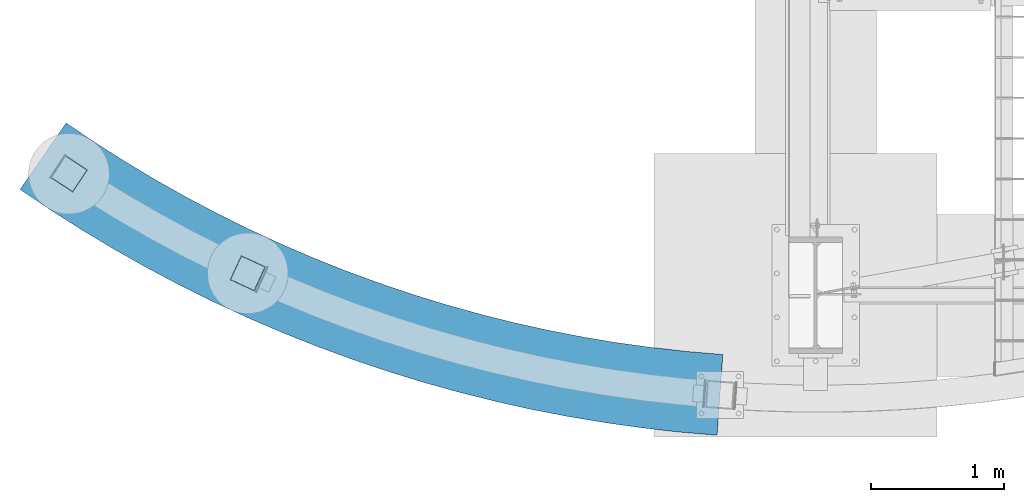
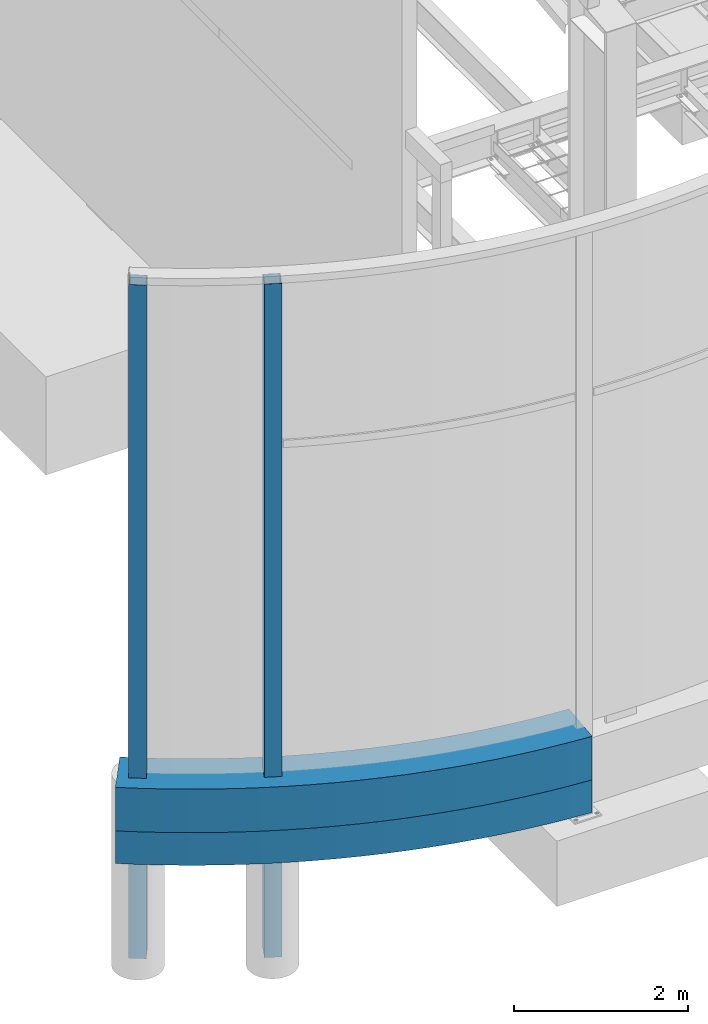
# One storey, part 699 of 1179: 4 beams, 4 elements without a shape of their own.
"""IFC2X3 building model written with IfcOpenShell, lengths in millimetres."""

from ifc_helpers import new_model, si_unit, frame, origin_with_axes, place, context, subcontext, project, spatial, faceted_brep, material, type_object, element, aggregate, save


model = new_model("IFC2X3")

# Units and contexts
model_context = context("Model", 3, precision=1e-05, world=origin_with_axes())
body_context = subcontext(model_context, "Body", "Model", "MODEL_VIEW")
ifc_project = project(units=[si_unit("LENGTHUNIT", "METRE", prefix="MILLI"), si_unit("AREAUNIT", "SQUARE_METRE"), si_unit("VOLUMEUNIT", "CUBIC_METRE"), si_unit("MASSUNIT", "GRAM", prefix="KILO"), si_unit("TIMEUNIT", "SECOND"), si_unit("PLANEANGLEUNIT", "RADIAN"), si_unit("SOLIDANGLEUNIT", "STERADIAN"), si_unit("THERMODYNAMICTEMPERATUREUNIT", "DEGREE_CELSIUS"), si_unit("LUMINOUSINTENSITYUNIT", "LUMEN")], contexts=[model_context])

# Site, building, storey
site_placement = place(None, origin_with_axes())
site = spatial("IfcSite", under=ifc_project, at=site_placement, CompositionType="ELEMENT")
building_placement = place(site_placement, origin_with_axes())
building = spatial("IfcBuilding", under=site, at=building_placement, Name="Undefined", CompositionType="ELEMENT")
storey_placement = place(building_placement, origin_with_axes())
storey = spatial("IfcBuildingStorey", under=building, at=storey_placement, Name="Undefined", CompositionType="ELEMENT", Elevation=0.0)

# Assembly, beam
assembly_1_placement = place(storey_placement, origin_with_axes())
assembly_1 = element("IfcElementAssembly", 1, at=assembly_1_placement, inside=storey, Name="GRADE_BEAM", AssemblyPlace="NOTDEFINED", PredefinedType="REINFORCEMENT_UNIT")
ifc_material_1 = material(Name="CONCRETE/5000")
beam_type_1 = type_object("IfcBeamType", PredefinedType="NOTDEFINED")
beam_1_placement = place(assembly_1_placement, frame((-5385.70183901794, 1486.40751131406, -889.000667008818), z_axis=(0.0, 0.0, 1.0), x_axis=(0.870964399060689, -0.491346126034237, 0.0)))
beam_1 = element("IfcBeam", 2, at=beam_1_placement, type_object=beam_type_1, material=ifc_material_1, Name="GRADE_BEAM", context=body_context, shape_type="Brep", body=[
    faceted_brep([(-28.3943633455974, -303.474546099302, -228.6), (-28.3943633455974, -303.474546099302, 228.6), (28.3943633455992, 303.474546099302, 228.6), (28.3943633455992, 303.474546099302, -228.6), (533.586879412836, -340.905096028998, 228.6), (815.127734137885, -348.318947941847, 228.6), (1096.76615721708, -348.189622933819, 228.6), (1378.30008451081, -340.517213790359, 228.6), (1659.52752685093, -325.307225153676, 228.6), (1940.24671495982, -302.570569573395, 228.6), (2220.25624421165, -272.323559677239, 228.6), (2499.35521913202, -234.58789646738, 228.6), (2777.34339753231, -189.390653750846, 228.6), (3054.02133417533, -136.764258715177, 228.6), (3329.19052386917, -76.7464686632229, 228.6), (3602.65354388665, -9.38034392381314, 228.6), (3874.21419560808, 65.2857830422784, 228.6), (4143.67764528583, 147.198342318925, 228.6), (4410.85056382963, 236.298564968867, 228.6), (4675.54126551235, 332.522525198057, 228.6), (4937.55984549674, 435.801186219816, 228.6), (5196.71831608441, 546.060449785929, 228.6), (5452.83074158937, 663.22120934911, 228.6), (5191.8374509015, 1214.12470563131, 228.6), (4950.57351669081, 1103.75651193046, 228.6), (4706.44013630243, 999.889689933523, 228.6), (4459.6124655298, 902.598759870332, 228.6), (4210.26759321038, 811.953524035127, 228.6), (3958.58441417162, 728.019016706227, 228.6), (3704.74350088112, 650.855457486552, 228.6), (3448.92697389325, 580.518208098538, 228.6), (3191.31837118505, 517.057732664323, 228.6), (2932.10251647516, 460.519561499791, 228.6), (2671.46538662031, 410.944258448426, 228.6), (2409.59397818447, 368.367391778388, 228.6), (2146.6761732764, 332.819508663741, 228.6), (1882.90060475187, 304.326113268078, 228.6), (1618.45652087724, 282.907648446329, 228.6), (1353.5336495515, 268.579481077837, 228.6), (1088.32206218421, 261.351891041251, 228.6), (823.012037326969, 261.230063839127, 228.6), (557.793924156288, 268.214086877534, 228.6), (292.858005905764, 282.298949403358, 228.6), (252.345587180221, -325.953386333161, 228.6), (292.858005905764, 282.298949403359, -228.6), (557.793924156288, 268.214086877534, -228.6), (823.01203732697, 261.230063839127, -228.6), (1088.32206218421, 261.351891041251, -228.6), (1353.5336495515, 268.579481077837, -228.6), (1618.45652087724, 282.907648446329, -228.6), (1882.90060475187, 304.326113268078, -228.6), (2146.6761732764, 332.819508663741, -228.6), (2409.59397818447, 368.367391778388, -228.6), (2671.46538662031, 410.944258448426, -228.6), (2932.10251647516, 460.519561499791, -228.6), (3191.31837118505, 517.057732664323, -228.6), (3448.92697389325, 580.518208098538, -228.6), (3704.74350088112, 650.855457486554, -228.6), (3958.58441417162, 728.019016706227, -228.6), (4210.26759321039, 811.95352403513, -228.6), (4459.6124655298, 902.598759870332, -228.6), (4706.44013630243, 999.889689933523, -228.6), (4950.57351669081, 1103.75651193046, -228.6), (5191.8374509015, 1214.12470563131, -228.6), (5452.83074158937, 663.22120934911, -228.6), (5196.71831608441, 546.060449785929, -228.6), (4937.55984549674, 435.801186219816, -228.6), (4675.54126551235, 332.522525198057, -228.6), (4410.85056382963, 236.298564968867, -228.6), (4143.67764528583, 147.198342318925, -228.6), (3874.21419560808, 65.2857830422784, -228.6), (3602.65354388665, -9.38034392381314, -228.6), (3329.19052386917, -76.7464686632229, -228.6), (3054.02133417533, -136.764258715177, -228.6), (2777.34339753231, -189.390653750846, -228.6), (2499.35521913202, -234.58789646738, -228.6), (2220.25624421165, -272.323559677239, -228.6), (1940.24671495982, -302.570569573395, -228.6), (1659.52752685093, -325.307225153676, -228.6), (1378.30008451081, -340.517213790359, -228.6), (1096.76615721708, -348.189622933819, -228.6), (815.127734137885, -348.318947941847, -228.6), (533.586879412836, -340.905096028998, -228.6), (252.345587180221, -325.953386333161, -228.6)], [[[0, 1, 2, 3]], [[4, 5, 6, 7, 8, 9, 10, 11, 12, 13, 14, 15, 16, 17, 18, 19, 20, 21, 22, 23, 24, 25, 26, 27, 28, 29, 30, 31, 32, 33, 34, 35, 36, 37, 38, 39, 40, 41, 42, 2, 1, 43]], [[3, 2, 42, 44]], [[45, 46, 47, 48, 49, 50, 51, 52, 53, 54, 55, 56, 57, 58, 59, 60, 61, 62, 63, 64, 65, 66, 67, 68, 69, 70, 71, 72, 73, 74, 75, 76, 77, 78, 79, 80, 81, 82, 83, 0, 3, 44]], [[1, 0, 83, 43]], [[83, 82, 4, 43]], [[42, 41, 45, 44]], [[82, 81, 5, 4]], [[41, 40, 46, 45]], [[81, 80, 6, 5]], [[40, 39, 47, 46]], [[80, 79, 7, 6]], [[39, 38, 48, 47]], [[79, 78, 8, 7]], [[38, 37, 49, 48]], [[78, 77, 9, 8]], [[37, 36, 50, 49]], [[77, 76, 10, 9]], [[36, 35, 51, 50]], [[76, 75, 11, 10]], [[35, 34, 52, 51]], [[75, 74, 12, 11]], [[34, 33, 53, 52]], [[74, 73, 13, 12]], [[33, 32, 54, 53]], [[73, 72, 14, 13]], [[32, 31, 55, 54]], [[72, 71, 15, 14]], [[31, 30, 56, 55]], [[71, 70, 16, 15]], [[30, 29, 57, 56]], [[70, 69, 17, 16]], [[29, 28, 58, 57]], [[69, 68, 18, 17]], [[28, 27, 59, 58]], [[68, 67, 19, 18]], [[27, 26, 60, 59]], [[67, 66, 20, 19]], [[26, 25, 61, 60]], [[66, 65, 21, 20]], [[25, 24, 62, 61]], [[22, 64, 63, 23]], [[65, 64, 22, 21]], [[24, 23, 63, 62]]]),
])
aggregate(assembly_1, [beam_1])

assembly_2_placement = place(storey_placement, origin_with_axes())
assembly_2 = element("IfcElementAssembly", 3, at=assembly_2_placement, inside=storey, Name="GRADE_BEAM", AssemblyPlace="NOTDEFINED", PredefinedType="REINFORCEMENT_UNIT")
beam_type_2 = type_object("IfcBeamType", PredefinedType="NOTDEFINED")
beam_2_placement = place(assembly_2_placement, frame((-5385.70183901794, 1486.40751131406, -355.600667008818), z_axis=(0.0, 0.0, 1.0), x_axis=(0.870964399060689, -0.491346126034237, 0.0)))
beam_2 = element("IfcBeam", 4, at=beam_2_placement, type_object=beam_type_2, material=ifc_material_1, Name="GRADE_BEAM", context=body_context, shape_type="Brep", body=[
    faceted_brep([(-28.3943633455974, -303.474546099302, -304.8), (-28.3943633455974, -303.474546099302, 304.8), (28.3943633455983, 303.474546099302, 304.8), (28.3943633455983, 303.474546099302, -304.8), (533.586879412836, -340.905096028996, 304.8), (815.127734137885, -348.318947941846, 304.8), (1096.76615721708, -348.189622933817, 304.8), (1378.30008451081, -340.517213790356, 304.8), (1659.52752685093, -325.307225153674, 304.8), (1940.24671495982, -302.570569573393, 304.8), (2220.25624421165, -272.323559677237, 304.8), (2499.35521913202, -234.587896467378, 304.8), (2777.34339753231, -189.390653750844, 304.8), (3054.02133417533, -136.764258715175, 304.8), (3329.19052386917, -76.7464686632211, 304.8), (3602.65354388665, -9.38034392381314, 304.8), (3874.21419560807, 65.2857830422802, 304.8), (4143.67764528583, 147.198342318925, 304.8), (4410.85056382963, 236.298564968867, 304.8), (4675.54126551235, 332.522525198058, 304.8), (4937.55984549674, 435.801186219818, 304.8), (5196.7183160844, 546.060449785928, 304.8), (5452.83074158938, 663.221209349111, 304.8), (5191.83745090149, 1214.12470563131, 304.8), (4950.57351669081, 1103.75651193046, 304.8), (4706.44013630243, 999.889689933523, 304.8), (4459.6124655298, 902.598759870334, 304.8), (4210.26759321039, 811.95352403513, 304.8), (3958.58441417162, 728.019016706227, 304.8), (3704.74350088112, 650.855457486552, 304.8), (3448.92697389325, 580.51820809854, 304.8), (3191.31837118505, 517.057732664325, 304.8), (2932.10251647516, 460.519561499793, 304.8), (2671.46538662031, 410.944258448426, 304.8), (2409.59397818447, 368.36739177839, 304.8), (2146.6761732764, 332.819508663743, 304.8), (1882.90060475187, 304.32611326808, 304.8), (1618.45652087724, 282.907648446332, 304.8), (1353.5336495515, 268.579481077839, 304.8), (1088.32206218421, 261.351891041253, 304.8), (823.012037326969, 261.230063839126, 304.8), (557.793924156287, 268.214086877535, 304.8), (292.858005905763, 282.29894940336, 304.8), (252.345587180223, -325.953386333161, 304.8), (292.858005905763, 282.29894940336, -304.8), (557.793924156287, 268.214086877535, -304.8), (823.012037326969, 261.230063839127, -304.8), (1088.32206218421, 261.351891041253, -304.8), (1353.5336495515, 268.579481077839, -304.8), (1618.45652087724, 282.907648446332, -304.8), (1882.90060475187, 304.32611326808, -304.8), (2146.6761732764, 332.819508663743, -304.8), (2409.59397818447, 368.36739177839, -304.8), (2671.46538662031, 410.944258448426, -304.8), (2932.10251647516, 460.519561499793, -304.8), (3191.31837118505, 517.057732664325, -304.8), (3448.92697389325, 580.51820809854, -304.8), (3704.74350088112, 650.855457486552, -304.8), (3958.58441417162, 728.019016706227, -304.8), (4210.26759321039, 811.953524035131, -304.8), (4459.6124655298, 902.598759870334, -304.8), (4706.44013630243, 999.889689933523, -304.8), (4950.57351669081, 1103.75651193046, -304.8), (5191.83745090149, 1214.12470563131, -304.8), (5452.83074158938, 663.221209349111, -304.8), (5196.7183160844, 546.060449785928, -304.8), (4937.55984549674, 435.801186219818, -304.8), (4675.54126551235, 332.522525198058, -304.8), (4410.85056382963, 236.298564968867, -304.8), (4143.67764528583, 147.198342318925, -304.8), (3874.21419560807, 65.2857830422802, -304.8), (3602.65354388665, -9.38034392381314, -304.8), (3329.19052386917, -76.7464686632211, -304.8), (3054.02133417533, -136.764258715175, -304.8), (2777.34339753231, -189.390653750844, -304.8), (2499.35521913202, -234.587896467378, -304.8), (2220.25624421165, -272.323559677237, -304.8), (1940.24671495982, -302.570569573393, -304.8), (1659.52752685093, -325.307225153674, -304.8), (1378.30008451081, -340.517213790356, -304.8), (1096.76615721708, -348.189622933817, -304.8), (815.127734137885, -348.318947941846, -304.8), (533.586879412836, -340.905096028996, -304.8), (252.345587180223, -325.953386333161, -304.8)], [[[0, 1, 2, 3]], [[4, 5, 6, 7, 8, 9, 10, 11, 12, 13, 14, 15, 16, 17, 18, 19, 20, 21, 22, 23, 24, 25, 26, 27, 28, 29, 30, 31, 32, 33, 34, 35, 36, 37, 38, 39, 40, 41, 42, 2, 1, 43]], [[3, 2, 42, 44]], [[45, 46, 47, 48, 49, 50, 51, 52, 53, 54, 55, 56, 57, 58, 59, 60, 61, 62, 63, 64, 65, 66, 67, 68, 69, 70, 71, 72, 73, 74, 75, 76, 77, 78, 79, 80, 81, 82, 83, 0, 3, 44]], [[1, 0, 83, 43]], [[83, 82, 4, 43]], [[42, 41, 45, 44]], [[82, 81, 5, 4]], [[41, 40, 46, 45]], [[81, 80, 6, 5]], [[40, 39, 47, 46]], [[80, 79, 7, 6]], [[39, 38, 48, 47]], [[79, 78, 8, 7]], [[38, 37, 49, 48]], [[78, 77, 9, 8]], [[37, 36, 50, 49]], [[77, 76, 10, 9]], [[36, 35, 51, 50]], [[76, 75, 11, 10]], [[35, 34, 52, 51]], [[75, 74, 12, 11]], [[34, 33, 53, 52]], [[74, 73, 13, 12]], [[33, 32, 54, 53]], [[73, 72, 14, 13]], [[32, 31, 55, 54]], [[72, 71, 15, 14]], [[31, 30, 56, 55]], [[71, 70, 16, 15]], [[30, 29, 57, 56]], [[70, 69, 17, 16]], [[29, 28, 58, 57]], [[69, 68, 18, 17]], [[28, 27, 59, 58]], [[68, 67, 19, 18]], [[27, 26, 60, 59]], [[67, 66, 20, 19]], [[26, 25, 61, 60]], [[66, 65, 21, 20]], [[25, 24, 62, 61]], [[22, 64, 63, 23]], [[65, 64, 22, 21]], [[24, 23, 63, 62]]]),
])
aggregate(assembly_2, [beam_2])

assembly_3_placement = place(storey_placement, origin_with_axes())
assembly_3 = element("IfcElementAssembly", 5, at=assembly_3_placement, inside=storey, Name="COLUMN", AssemblyPlace="NOTDEFINED", PredefinedType="RIGID_FRAME")
ifc_material_2 = material()
beam_type_3 = type_object("IfcBeamType", Name="HSS8X8X1/4", PredefinedType="NOTDEFINED")
beam_3_placement = place(assembly_3_placement, frame((-3844.53874525558, 604.29605066736, -2584.45000499055), z_axis=(0.419404281142657, 0.90779956430878, 0.0), x_axis=(0.0, 0.0, 1.0)))
beam_3 = element("IfcBeam", 6, at=beam_3_placement, type_object=beam_type_3, material=ifc_material_2, Name="COLUMN", ObjectType="HSS8X8X1/4", context=body_context, shape_type="Brep", body=[
    faceted_brep([(6.35000000324453, 95.2499999999886, -95.250000000002), (6.3500000077338, -95.2500000000277, -95.2500000000118), (9442.45000499076, -95.24999999993, -95.2499999997469), (9442.45000499072, 95.2500000000864, -95.2499999997372), (6.35000014090519, -95.2499999999891, 95.2500000000022), (9442.45000499072, -95.2499999998913, 95.2500000002672), (6.35000013641593, 95.2500000000273, 95.2500000000119), (9442.45000499068, 95.2500000001251, 95.2500000002769), (6.34999999865568, 101.599999999989, -101.600000000002), (6.35000014070511, 101.60000000003, 101.600000000013), (9442.45000499068, 101.600000000127, 101.600000000277), (9442.45000499072, 101.600000000085, -101.599999999737), (6.35000014549405, -101.599999999989, 101.600000000002), (9442.45000499072, -101.599999999891, 101.600000000267), (6.35000000344462, -101.600000000029, -101.600000000013), (9442.45000499076, -101.599999999932, -101.599999999748)], [[[0, 1, 2, 3]], [[1, 4, 5, 2]], [[4, 6, 7, 5]], [[6, 0, 3, 7]], [[8, 9, 10, 11]], [[9, 12, 13, 10]], [[12, 14, 15, 13]], [[14, 8, 11, 15]], [[13, 15, 11, 10], [5, 7, 3, 2]], [[14, 12, 9, 8], [6, 4, 1, 0]]]),
])
aggregate(assembly_3, [beam_3])

assembly_4_placement = place(storey_placement, origin_with_axes())
assembly_4 = element("IfcElementAssembly", 7, at=assembly_4_placement, inside=storey, Name="COLUMN", AssemblyPlace="NOTDEFINED", PredefinedType="RIGID_FRAME")
beam_4_placement = place(assembly_4_placement, frame((-5190.66054580294, 1354.32492500995, -2584.45000499055), z_axis=(0.55123876077572, 0.834347546660532, 1.50000002619881e-08), x_axis=(0.0, 0.0, 1.0)))
beam_4 = element("IfcBeam", 8, at=beam_4_placement, type_object=beam_type_3, material=ifc_material_2, Name="COLUMN", ObjectType="HSS8X8X1/4", context=body_context, shape_type="Brep", body=[
    faceted_brep([(6.35000000324453, 95.2499999999886, -95.250000000002), (6.3500000077338, -95.2500000000277, -95.2500000000118), (9442.45000499076, -95.24999999993, -95.2499999997469), (9442.45000499072, 95.2500000000864, -95.2499999997372), (6.35000014090519, -95.2499999999891, 95.2500000000022), (9442.45000499072, -95.2499999998913, 95.2500000002672), (6.35000013641593, 95.2500000000273, 95.2500000000119), (9442.45000499068, 95.2500000001251, 95.2500000002769), (6.34999999865568, 101.599999999989, -101.600000000002), (6.35000014070511, 101.60000000003, 101.600000000013), (9442.45000499068, 101.600000000127, 101.600000000277), (9442.45000499072, 101.600000000085, -101.599999999737), (6.35000014549405, -101.599999999989, 101.600000000002), (9442.45000499072, -101.599999999891, 101.600000000267), (6.35000000344462, -101.600000000029, -101.600000000013), (9442.45000499076, -101.599999999932, -101.599999999748)], [[[0, 1, 2, 3]], [[1, 4, 5, 2]], [[4, 6, 7, 5]], [[6, 0, 3, 7]], [[8, 9, 10, 11]], [[9, 12, 13, 10]], [[12, 14, 15, 13]], [[14, 8, 11, 15]], [[13, 15, 11, 10], [5, 7, 3, 2]], [[14, 12, 9, 8], [6, 4, 1, 0]]]),
])
aggregate(assembly_4, [beam_4])

save(model, "model.ifc")
